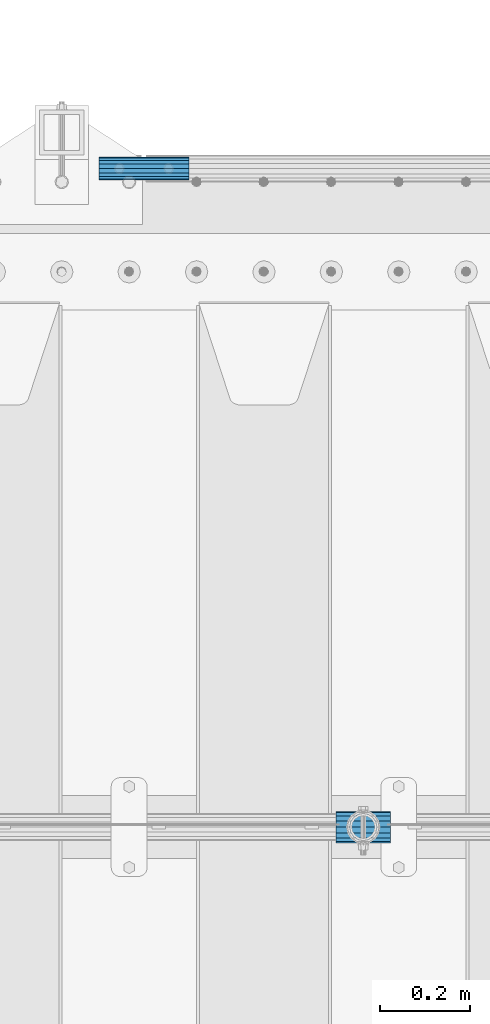
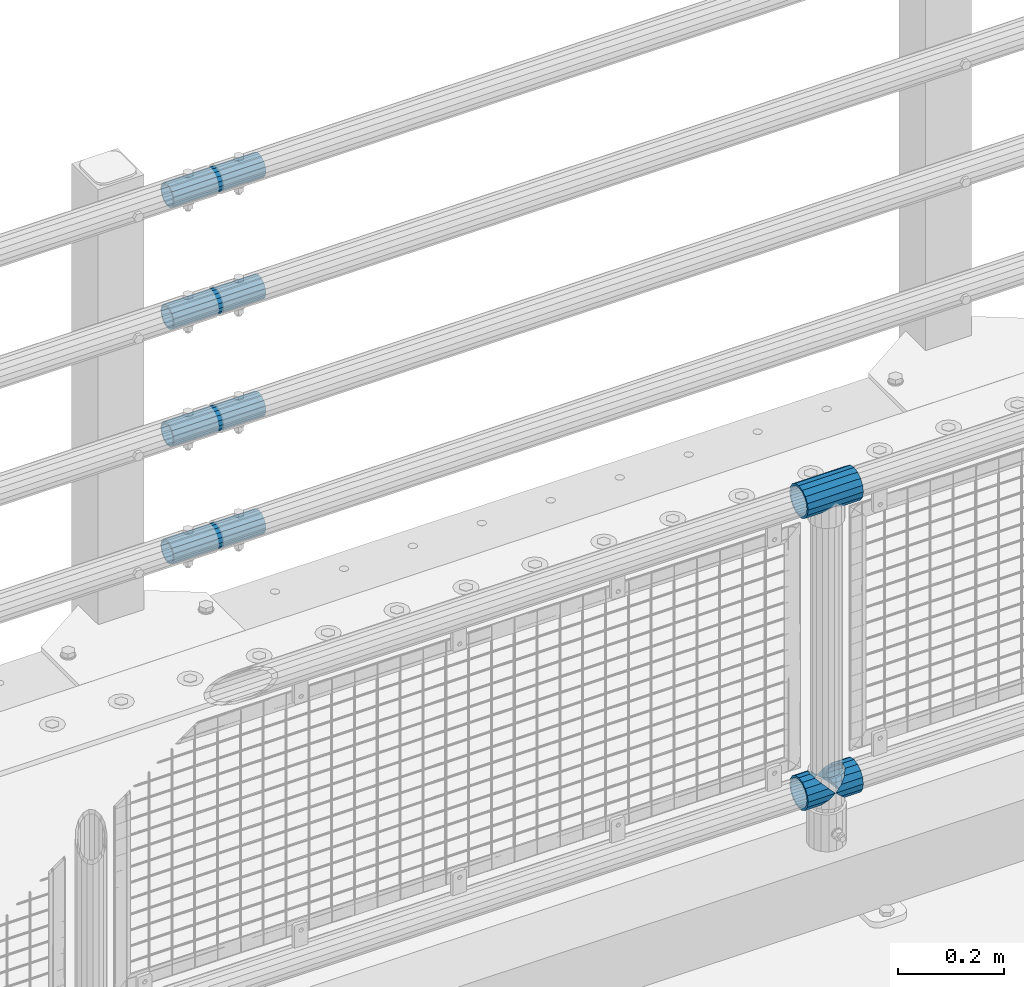
# One storey, part 127 of 208: 7 beams.
"""IFC2X3 building model written with IfcOpenShell, lengths in millimetres."""

from ifc_helpers import new_model, si_unit, frame, origin_with_axes, place, context, subcontext, project, spatial, faceted_brep, material, type_object, element, save


model = new_model("IFC2X3")

# Units and contexts
model_context = context("Model", 3, precision=1e-05, world=origin_with_axes())
body_context = subcontext(model_context, "Body", "Model", "MODEL_VIEW")
ifc_project = project(units=[si_unit("LENGTHUNIT", "METRE", prefix="MILLI"), si_unit("AREAUNIT", "SQUARE_METRE"), si_unit("VOLUMEUNIT", "CUBIC_METRE"), si_unit("MASSUNIT", "GRAM", prefix="KILO"), si_unit("TIMEUNIT", "SECOND"), si_unit("PLANEANGLEUNIT", "RADIAN"), si_unit("SOLIDANGLEUNIT", "STERADIAN"), si_unit("THERMODYNAMICTEMPERATUREUNIT", "DEGREE_CELSIUS"), si_unit("LUMINOUSINTENSITYUNIT", "LUMEN")], contexts=[model_context])

# Site, building, storey
site_placement = place(None, origin_with_axes())
site = spatial("IfcSite", under=ifc_project, at=site_placement, CompositionType="ELEMENT")
building_placement = place(site_placement, origin_with_axes())
building = spatial("IfcBuilding", under=site, at=building_placement, Name="Standard", CompositionType="ELEMENT")
storey_placement = place(building_placement, origin_with_axes())
storey = spatial("IfcBuildingStorey", under=building, at=storey_placement, Name="Undefined", CompositionType="ELEMENT", Elevation=0.0)

# Beams
ifc_material_1 = material(Name="Misc_Undefined")
beam_type_1 = type_object("IfcBeamType", PredefinedType="NOTDEFINED")
beam_1_placement = place(storey_placement, frame((-32289.15, 4664.5, 969.849999999999), z_axis=(0.0, 0.0, 1.0), x_axis=(1.0, 0.0, 0.0)))
element("IfcBeam", 1, at=beam_1_placement, inside=storey, type_object=beam_type_1, material=ifc_material_1, context=body_context, shape_type="Brep", body=[
    faceted_brep([(88.1897438117194, -11.6144421722802, -28.0397438117176), (88.1897438117194, -11.6144421722802, -32.8397438117178), (86.9623795176776, -13.4513226476329, -32.4743655677718), (81.6106908090114, -21.4606908090118, -27.1226768591068), (81.6106908090114, -21.4606908090118, -21.4606908090117), (76.531042407998, -24.8548033587067, -24.8548033587072), (71.7644421722835, -28.0397438117179, -20.0882031229861), (71.7644421722835, -28.0397438117179, -11.6144421722805), (60.1500000000015, -30.3500000000004, -16.6306603983687), (60.1500000000015, -30.35, 0.0), (48.5355578277195, -28.0397438117179, -20.0882031229861), (48.5355578277195, -28.0397438117179, -11.6144421722805), (43.7689575919976, -24.8548033587067, -24.8548033587072), (38.6893091909915, -21.4606908090118, -27.1226768591068), (38.6893091909915, -21.4606908090118, -21.4606908090117), (33.3376204823217, -13.4513226476329, -32.4743655677718), (32.1102561882835, -11.6144421722802, -32.8397438117178), (32.1102561882835, -11.6144421722802, -28.0397438117176), (29.8000000000029, 0.0, -35.15), (29.8000000000029, 0.0, -30.35), (32.1102561882835, 11.6144421722802, -32.8397438117175), (32.1102561882835, 11.6144421722802, -28.0397438117176), (33.3376204823217, 13.4513226476329, -32.4743655677718), (38.6893091909915, 21.4606908090118, -27.122676859108), (38.6893091909915, 21.4606908090118, -21.4606908090117), (43.7689575920012, 24.8548033587067, -24.8548033587072), (48.5355578277195, 28.0397438117179, -20.0882031229838), (48.5355578277195, 28.0397438117179, -11.6144421722805), (60.1500000000015, 30.3500000000004, -16.6306603983671), (60.1500000000015, 30.35, 0.0), (71.7644421722835, 28.0397438117179, -20.0882031229838), (71.7644421722835, 28.0397438117179, -11.6144421722805), (76.5310424080089, 24.8548033587067, -24.8548033587072), (81.6106908090114, 21.4606908090118, -27.122676859108), (81.6106908090114, 21.4606908090118, -21.4606908090117), (86.9623795176776, 13.4513226476329, -32.4743655677718), (88.1897438117194, 11.6144421722802, -32.8397438117175), (88.1897438117194, 11.6144421722802, -28.0397438117176), (90.5, 0.0, -35.15), (90.5, 0.0, -30.35), (0.0, -21.4606908090118, -21.4606908090136), (0.0, -28.0397438117179, -11.6144421722784), (0.0, -11.6144421722802, -28.0397438117143), (0.0, 0.0, -30.3499999999985), (0.0, 11.6144421722802, -28.0397438117143), (0.0, 21.4606908090118, -21.4606908090136), (0.0, 28.0397438117179, -11.6144421722784), (0.0, 30.3500000000004, 0.0), (0.0, 32.4743655677721, -13.4513226476338), (0.0, 35.1499999999996, 0.0), (120.299999999999, 35.1499999999996, 0.0), (120.299999999999, 32.4743655677721, -13.4513226476329), (0.0, 32.4743655677721, 13.4513226476338), (120.299999999999, 32.4743655677721, 13.4513226476329), (0.0, 24.8548033587067, 24.8548033587067), (120.299999999999, 24.8548033587067, 24.8548033587072), (0.0, 13.4513226476329, 32.4743655677739), (120.299999999999, 13.4513226476329, 32.4743655677718), (0.0, 0.0, 35.1499999999996), (120.299999999999, 0.0, 35.15), (0.0, -13.4513226476329, 32.4743655677739), (120.299999999999, -13.4513226476329, 32.4743655677718), (0.0, -24.8548033587067, 24.8548033587067), (120.299999999999, -24.8548033587067, 24.8548033587072), (0.0, -32.4743655677721, 13.4513226476338), (120.299999999999, -32.4743655677721, 13.4513226476329), (0.0, -35.1499999999996, 0.0), (120.299999999999, -35.1499999999996, 0.0), (0.0, -32.4743655677721, -13.4513226476338), (120.299999999999, -32.4743655677721, -13.4513226476329), (0.0, 24.8548033587067, -24.8548033587067), (0.0, 13.4513226476329, -32.4743655677739), (0.0, 0.0, -35.1499999999996), (0.0, -13.4513226476329, -32.4743655677739), (0.0, -24.8548033587067, -24.8548033587067), (0.0, 28.0397438117179, 11.6144421722784), (0.0, 21.4606908090118, 21.4606908090136), (0.0, 11.6144421722802, 28.0397438117143), (0.0, 0.0, 30.3499999999985), (0.0, -11.6144421722802, 28.0397438117143), (0.0, -21.4606908090118, 21.4606908090136), (0.0, -28.0397438117179, 11.6144421722784), (0.0, -30.3500000000004, 0.0), (120.299999999999, -30.3500000000004, 0.0), (120.299999999999, -28.0397438117179, -11.6144421722805), (120.299999999999, -21.4606908090118, -21.4606908090117), (120.299999999999, -11.6144421722802, -28.0397438117176), (120.299999999999, 0.0, -30.35), (120.299999999999, 21.4606908090118, -21.4606908090117), (120.299999999999, 28.0397438117179, -11.6144421722805), (120.299999999999, 11.6144421722802, -28.0397438117176), (120.299999999999, 30.3500000000004, 0.0), (120.299999999999, 28.0397438117179, 11.6144421722805), (120.299999999999, 21.4606908090118, 21.4606908090117), (120.299999999999, 11.6144421722802, 28.0397438117176), (120.299999999999, 0.0, 30.35), (120.299999999999, -11.6144421722802, 28.0397438117176), (120.299999999999, -21.4606908090118, 21.4606908090117), (120.299999999999, -28.0397438117179, 11.6144421722805), (120.299999999999, -24.8548033587067, -24.8548033587072), (120.299999999999, -13.4513226476329, -32.4743655677718), (120.299999999999, 0.0, -35.15), (120.299999999999, 13.4513226476329, -32.4743655677718), (120.299999999999, 24.8548033587067, -24.8548033587072)], [[[0, 1, 2, 3, 4]], [[4, 3, 5, 6, 7]], [[7, 6, 8, 9]], [[9, 8, 10, 11]], [[11, 10, 12, 13, 14]], [[14, 13, 15, 16, 17]], [[17, 16, 18, 19]], [[19, 18, 20, 21]], [[21, 20, 22, 23, 24]], [[24, 23, 25, 26, 27]], [[27, 26, 28, 29]], [[29, 28, 30, 31]], [[31, 30, 32, 33, 34]], [[34, 33, 35, 36, 37]], [[37, 36, 38, 39]], [[39, 38, 1, 0]], [[40, 41, 11, 14]], [[42, 40, 14, 17]], [[43, 42, 17, 19]], [[44, 43, 19, 21]], [[45, 44, 21, 24]], [[46, 45, 24, 27]], [[47, 46, 27, 29]], [[48, 49, 50, 51]], [[49, 52, 53, 50]], [[52, 54, 55, 53]], [[54, 56, 57, 55]], [[56, 58, 59, 57]], [[58, 60, 61, 59]], [[60, 62, 63, 61]], [[62, 64, 65, 63]], [[64, 66, 67, 65]], [[66, 68, 69, 67]], [[64, 62, 60, 58, 56, 54, 52, 49, 48, 70, 71, 72, 73, 74, 68, 66], [41, 40, 42, 43, 44, 45, 46, 47, 75, 76, 77, 78, 79, 80, 81, 82]], [[41, 82, 9, 11]], [[83, 84, 7, 9]], [[84, 85, 4, 7]], [[85, 86, 0, 4]], [[86, 87, 39, 0]], [[88, 89, 31, 34]], [[90, 88, 34, 37]], [[87, 90, 37, 39]], [[89, 91, 29, 31]], [[75, 47, 29, 91, 92]], [[76, 75, 92, 93]], [[77, 76, 93, 94]], [[78, 77, 94, 95]], [[79, 78, 95, 96]], [[80, 79, 96, 97]], [[81, 80, 97, 98]], [[9, 82, 81, 98, 83]], [[99, 100, 101, 102, 103, 51, 50, 53, 55, 57, 59, 61, 63, 65, 67, 69], [97, 96, 95, 94, 93, 92, 91, 89, 88, 90, 87, 86, 85, 84, 83, 98]], [[35, 102, 101, 38, 36]], [[32, 103, 102, 35, 33]], [[28, 26, 25, 70, 48, 51, 103, 32, 30]], [[22, 71, 70, 25, 23]], [[18, 72, 71, 22, 20]], [[73, 72, 18, 16, 15]], [[74, 73, 15, 13, 12]], [[99, 69, 68, 74, 12, 10, 8, 6, 5]], [[100, 99, 5, 3, 2]], [[101, 100, 2, 1, 38]]]),
])
beam_2_placement = place(storey_placement, frame((-32289.15, 4664.5, 298.17), z_axis=(0.0, 1.0, 0.0), x_axis=(1.0, 0.0, 0.0)))
element("IfcBeam", 2, at=beam_2_placement, inside=storey, type_object=beam_type_1, material=ifc_material_1, context=body_context, shape_type="Brep", body=[
    faceted_brep([(60.1500000000015, 0.0, -35.1499999999996), (46.6986773523677, 13.4513226476329, -32.4743655677721), (46.6986773523677, -13.4513226476329, -32.4743655677721), (33.0273231408937, 21.4606908090117, 21.4606908090118), (27.6756344322275, 26.812379517676, 13.4513226476329), (27.6756344322275, 32.4743655677717, 13.4513226476329), (35.2951966412948, 24.8548033587072, 24.8548033587067), (35.2951966412948, 16.3810424080032, 24.8548033587067), (27.3102561882915, 28.0397438117175, 11.6144421722802), (25.0, 30.35, 0.0), (25.0, 35.15, 0.0), (27.6756344322275, 26.8123795176755, -13.4513226476329), (27.6756344322275, 32.4743655677717, -13.4513226476329), (27.3102561882843, 28.0397438117175, -11.6144421722802), (35.2951966412948, 16.3810424080024, -24.8548033587067), (35.2951966412948, 24.8548033587072, -24.8548033587067), (33.0273231408864, 21.4606908090117, -21.4606908090118), (40.0617968770239, 11.6144421722805, -28.0397438117179), (43.5193396016402, 0.0, -30.3500000000004), (40.0617968770239, -11.6144421722805, -28.0397438117179), (35.2951966412948, -16.3810424080032, -24.8548033587067), (35.2951966412948, -24.8548033587072, -24.8548033587067), (33.0273231408864, -21.4606908090117, -21.4606908090118), (27.6756344322275, -26.812379517676, -13.4513226476329), (27.6756344322275, -32.4743655677717, -13.4513226476329), (27.3102561882843, -28.0397438117175, -11.6144421722802), (25.0, -30.35, 0.0), (25.0, -35.15, 0.0), (27.3102561882915, -28.0397438117175, 11.6144421722802), (27.6756344322275, -26.8123795176755, 13.4513226476329), (27.6756344322275, -32.4743655677717, 13.4513226476329), (33.0273231408937, -21.4606908090117, 21.4606908090118), (35.2951966412948, -16.3810424080032, 24.8548033587067), (35.2951966412948, -24.8548033587072, 24.8548033587067), (60.1500000000015, 0.0, 35.1499999999996), (46.6986773523677, -13.4513226476329, 32.4743655677721), (46.6986773523677, 13.4513226476329, 32.4743655677721), (40.0617968770093, -11.6144421722805, 28.0397438117179), (43.519339601633, 0.0, 30.3500000000004), (40.0617968770093, 11.6144421722805, 28.0397438117179), (0.0, -32.4743655677721, -13.4513226476338), (0.0, -24.8548033587067, -24.8548033587067), (0.0, -13.4513226476329, -32.4743655677739), (0.0, 0.0, -35.1499999999996), (0.0, 13.4513226476329, -32.4743655677739), (0.0, 24.8548033587067, -24.8548033587067), (0.0, 32.4743655677721, -13.4513226476338), (0.0, 35.1499999999996, 0.0), (0.0, 32.4743655677721, 13.4513226476338), (0.0, 24.8548033587067, 24.8548033587067), (0.0, 13.4513226476329, 32.4743655677739), (0.0, 0.0, 35.1499999999996), (0.0, -32.4743655677721, 13.4513226476338), (0.0, -35.1499999999996, 0.0), (0.0, -24.8548033587067, 24.8548033587067), (0.0, -13.4513226476329, 32.4743655677739), (0.0, -28.0397438117179, -11.6144421722784), (0.0, -21.4606908090118, -21.4606908090136), (0.0, -11.6144421722802, -28.0397438117143), (0.0, 0.0, -30.3499999999985), (0.0, 11.6144421722802, -28.0397438117143), (0.0, 21.4606908090118, -21.4606908090136), (0.0, 28.0397438117179, -11.6144421722784), (0.0, 30.3500000000004, 0.0), (0.0, 28.0397438117179, 11.6144421722784), (0.0, 21.4606908090118, 21.4606908090136), (0.0, 11.6144421722802, 28.0397438117143), (0.0, 0.0, 30.3499999999985), (0.0, -11.6144421722802, 28.0397438117143), (0.0, -21.4606908090118, 21.4606908090136), (0.0, -28.0397438117179, 11.6144421722784), (0.0, -30.3500000000004, 0.0)], [[[0, 1, 2]], [[3, 4, 5, 6, 7]], [[8, 9, 10, 5, 4]], [[11, 12, 10, 9, 13]], [[14, 15, 12, 11, 16]], [[2, 1, 15, 14, 17, 18, 19, 20, 21]], [[21, 20, 22, 23, 24]], [[24, 23, 25, 26, 27]], [[27, 26, 28, 29, 30]], [[30, 29, 31, 32, 33]], [[34, 35, 36]], [[33, 32, 37, 38, 39, 7, 6, 36, 35]], [[40, 41, 21, 24]], [[41, 42, 2, 21]], [[42, 43, 0, 2]], [[43, 44, 1, 0]], [[44, 45, 15, 1]], [[45, 46, 12, 15]], [[46, 47, 10, 12]], [[47, 48, 5, 10]], [[48, 49, 6, 5]], [[49, 50, 36, 6]], [[50, 51, 34, 36]], [[52, 53, 27, 30]], [[54, 52, 30, 33]], [[55, 54, 33, 35]], [[51, 55, 35, 34]], [[53, 40, 24, 27]], [[52, 54, 55, 51, 50, 49, 48, 47, 46, 45, 44, 43, 42, 41, 40, 53], [56, 57, 58, 59, 60, 61, 62, 63, 64, 65, 66, 67, 68, 69, 70, 71]], [[68, 67, 38, 37]], [[31, 69, 68, 37, 32]], [[28, 70, 69, 31, 29]], [[71, 70, 28, 26]], [[56, 71, 26, 25]], [[57, 56, 25, 23, 22]], [[58, 57, 22, 20, 19]], [[59, 58, 19, 18]], [[60, 59, 18, 17]], [[16, 61, 60, 17, 14]], [[13, 62, 61, 16, 11]], [[63, 62, 13, 9]], [[64, 63, 9, 8]], [[65, 64, 8, 4, 3]], [[66, 65, 3, 7, 39]], [[67, 66, 39, 38]]]),
])
beam_3_placement = place(storey_placement, frame((-32229.0, 4664.5, 298.17), z_axis=(0.0, 1.0, 0.0), x_axis=(1.0, 0.0, 0.0)))
element("IfcBeam", 3, at=beam_3_placement, inside=storey, type_object=beam_type_1, material=ifc_material_1, context=body_context, shape_type="Brep", body=[
    faceted_brep([(0.0, 0.0, 35.1499999999996), (13.4513226476338, 13.4513226476329, 32.4743655677721), (13.4513226476338, -13.4513226476329, 32.4743655677721), (32.4743655677739, -32.4743655677717, -13.4513226476329), (32.4743655677739, -26.8123795176766, -13.4513226476329), (27.1226768591077, -21.4606908090117, -21.4606908090118), (24.8548033587067, -16.3810424080039, -24.8548033587067), (24.8548033587067, -24.8548033587072, -24.8548033587067), (13.4513226476338, -13.4513226476329, -32.4743655677721), (13.4513226476338, 13.4513226476329, -32.4743655677721), (0.0, 0.0, -35.1499999999996), (20.0882031229849, -11.6144421722805, -28.0397438117179), (16.6306603983685, 0.0, -30.3500000000004), (20.0882031229849, 11.6144421722805, -28.0397438117179), (24.8548033587067, 16.3810424080023, -24.8548033587067), (24.8548033587067, 24.8548033587072, -24.8548033587067), (32.4743655677739, 26.8123795176755, -13.4513226476329), (32.4743655677739, 32.4743655677717, -13.4513226476329), (27.1226768591077, 21.4606908090117, -21.4606908090118), (35.1500000000015, 30.35, 0.0), (35.1500000000015, 35.15, 0.0), (32.8397438117172, 28.0397438117175, -11.6144421722802), (32.8397438117172, 28.0397438117175, 11.6144421722802), (32.4743655677739, 26.812379517676, 13.4513226476329), (32.4743655677739, 32.4743655677717, 13.4513226476329), (27.1226768591005, 21.4606908090117, 21.4606908090118), (24.8548033587067, 16.3810424080032, 24.8548033587067), (24.8548033587067, 24.8548033587072, 24.8548033587067), (20.0882031229921, 11.6144421722805, 28.0397438117179), (16.6306603983685, 0.0, 30.3500000000004), (20.0882031229921, -11.6144421722805, 28.0397438117179), (24.8548033587067, -16.3810424080039, 24.8548033587067), (24.8548033587067, -24.8548033587072, 24.8548033587067), (27.1226768591005, -21.4606908090117, 21.4606908090118), (32.4743655677739, -26.8123795176755, 13.4513226476329), (32.4743655677739, -32.4743655677717, 13.4513226476329), (32.8397438117172, -28.0397438117175, 11.6144421722802), (35.1500000000015, -30.35, 0.0), (35.1500000000015, -35.1499999999996, 0.0), (32.8397438117172, -28.0397438117175, -11.6144421722802), (60.1500000000015, -24.8548033587072, -24.8548033587067), (60.1500000000015, -32.4743655677717, -13.4513226476329), (60.1500000000015, -13.4513226476329, -32.4743655677721), (60.1500000000015, 0.0, -35.1499999999996), (60.1500000000015, 13.4513226476329, -32.4743655677721), (60.1500000000015, 24.8548033587072, -24.8548033587067), (60.1500000000015, 32.4743655677717, -13.4513226476329), (60.1500000000015, 35.15, 0.0), (60.1500000000015, 32.4743655677717, 13.4513226476329), (60.1500000000015, 24.8548033587072, 24.8548033587067), (60.1500000000015, 13.4513226476329, 32.4743655677721), (60.1500000000015, 0.0, 35.1499999999996), (60.1500000000015, -13.4513226476329, 32.4743655677721), (60.1500000000015, -24.8548033587072, 24.8548033587067), (60.1500000000015, -32.4743655677717, 13.4513226476329), (60.1500000000015, -35.15, 0.0), (60.1500000000015, -21.4606908090117, 21.4606908090118), (60.1500000000015, -11.6144421722805, 28.0397438117179), (60.1500000000015, 0.0, 30.3500000000004), (60.1500000000015, 11.6144421722805, 28.0397438117179), (60.1500000000015, 21.4606908090117, 21.4606908090118), (60.1500000000015, 28.0397438117175, 11.6144421722802), (60.1500000000015, 30.35, 0.0), (60.1500000000015, 28.0397438117175, -11.6144421722802), (60.1500000000015, 21.4606908090117, -21.4606908090118), (60.1500000000015, 11.6144421722805, -28.0397438117179), (60.1500000000015, 0.0, -30.3500000000004), (60.1500000000015, -11.6144421722805, -28.0397438117179), (60.1500000000015, -21.4606908090117, -21.4606908090118), (60.1500000000015, -28.0397438117175, -11.6144421722802), (60.1500000000015, -30.35, 0.0), (60.1500000000015, -28.0397438117175, 11.6144421722802)], [[[0, 1, 2]], [[3, 4, 5, 6, 7]], [[8, 9, 10]], [[7, 6, 11, 12, 13, 14, 15, 9, 8]], [[16, 17, 15, 14, 18]], [[19, 20, 17, 16, 21]], [[22, 23, 24, 20, 19]], [[25, 26, 27, 24, 23]], [[2, 1, 27, 26, 28, 29, 30, 31, 32]], [[32, 31, 33, 34, 35]], [[35, 34, 36, 37, 38]], [[38, 37, 39, 4, 3]], [[40, 41, 3, 7]], [[42, 40, 7, 8]], [[43, 42, 8, 10]], [[44, 43, 10, 9]], [[45, 44, 9, 15]], [[46, 45, 15, 17]], [[47, 46, 17, 20]], [[48, 47, 20, 24]], [[49, 48, 24, 27]], [[50, 49, 27, 1]], [[51, 50, 1, 0]], [[52, 51, 0, 2]], [[53, 52, 2, 32]], [[54, 53, 32, 35]], [[55, 54, 35, 38]], [[41, 55, 38, 3]], [[40, 42, 43, 44, 45, 46, 47, 48, 49, 50, 51, 52, 53, 54, 55, 41], [56, 57, 58, 59, 60, 61, 62, 63, 64, 65, 66, 67, 68, 69, 70, 71]], [[71, 70, 37, 36]], [[33, 56, 71, 36, 34]], [[30, 57, 56, 33, 31]], [[58, 57, 30, 29]], [[59, 58, 29, 28]], [[60, 59, 28, 26, 25]], [[61, 60, 25, 23, 22]], [[62, 61, 22, 19]], [[63, 62, 19, 21]], [[18, 64, 63, 21, 16]], [[13, 65, 64, 18, 14]], [[66, 65, 13, 12]], [[67, 66, 12, 11]], [[68, 67, 11, 6, 5]], [[69, 68, 5, 4, 39]], [[70, 69, 39, 37]]]),
])
ifc_material_2 = material()
beam_type_2 = type_object("IfcBeamType", PredefinedType="NOTDEFINED")
beam_4_placement = place(storey_placement, frame((-32817.0024970001, 6129.8500000004, 149.849999999725), z_axis=(0.0, 0.0, 1.0), x_axis=(1.0, 0.0, 0.0)))
element("IfcBeam", 4, at=beam_4_placement, inside=storey, type_object=beam_type_2, material=ifc_material_2, context=body_context, shape_type="Brep", body=[
    faceted_brep([(0.0, -21.8999999999996, 0.0), (0.0, -20.2329617619971, 8.38076716879547), (200.0, -20.2329617619971, 8.38076716879547), (200.0, -21.8999999999996, 0.0), (0.0, -15.4856385079856, 15.4856385079854), (200.0, -15.4856385079856, 15.4856385079854), (0.0, -8.3807671687955, 20.2329617619972), (200.0, -8.3807671687955, 20.2329617619972), (0.0, 0.0, 21.9), (200.0, 0.0, 21.9), (0.0, 8.3807671687955, 20.2329617619972), (200.0, 8.3807671687955, 20.2329617619972), (0.0, 15.4856385079856, 15.4856385079854), (200.0, 15.4856385079856, 15.4856385079854), (0.0, 20.2329617619971, 8.38076716879547), (200.0, 20.2329617619971, 8.38076716879547), (0.0, 21.8999999999996, 0.0), (200.0, 21.8999999999996, 0.0), (0.0, 20.2329617619971, -8.38076716879547), (200.0, 20.2329617619971, -8.38076716879547), (0.0, 15.4856385079856, -15.4856385079854), (200.0, 15.4856385079856, -15.4856385079854), (0.0, 8.3807671687955, -20.2329617619972), (200.0, 8.3807671687955, -20.2329617619972), (0.0, 0.0, -21.9), (200.0, 0.0, -21.9), (0.0, -8.3807671687955, -20.2329617619972), (200.0, -8.3807671687955, -20.2329617619972), (0.0, -15.4856385079856, -15.4856385079854), (200.0, -15.4856385079856, -15.4856385079854), (0.0, -20.2329617619971, -8.38076716879547), (200.0, -20.2329617619971, -8.38076716879547), (0.0, -25.5, 0.0), (0.0, -23.5589280790382, -9.7584275253098), (200.0, -23.5589280790382, -9.7584275253098), (200.0, -25.5, 0.0), (0.0, -18.0312229202573, -18.031222920257), (200.0, -18.0312229202573, -18.031222920257), (0.0, -9.75842752530934, -23.5589280790378), (200.0, -9.75842752530934, -23.5589280790378), (0.0, 0.0, -25.5), (200.0, 0.0, -25.5), (0.0, 9.75842752531025, -23.5589280790378), (200.0, 9.75842752531025, -23.5589280790378), (0.0, 18.0312229202573, -18.031222920257), (200.0, 18.0312229202573, -18.031222920257), (0.0, 23.5589280790382, -9.7584275253098), (200.0, 23.5589280790382, -9.7584275253098), (0.0, 25.5, 0.0), (200.0, 25.5, 0.0), (0.0, 23.5589280790382, 9.7584275253098), (200.0, 23.5589280790382, 9.7584275253098), (0.0, 18.0312229202573, 18.031222920257), (200.0, 18.0312229202573, 18.031222920257), (0.0, 9.75842752530934, 23.5589280790378), (200.0, 9.75842752530934, 23.5589280790378), (0.0, 0.0, 25.5), (200.0, 0.0, 25.5), (0.0, -9.75842752530934, 23.5589280790378), (200.0, -9.75842752530934, 23.5589280790378), (0.0, -18.0312229202573, 18.031222920257), (200.0, -18.0312229202573, 18.031222920257), (0.0, -23.5589280790382, 9.7584275253098), (200.0, -23.5589280790382, 9.7584275253098)], [[[0, 1, 2, 3]], [[1, 4, 5, 2]], [[4, 6, 7, 5]], [[6, 8, 9, 7]], [[8, 10, 11, 9]], [[10, 12, 13, 11]], [[12, 14, 15, 13]], [[14, 16, 17, 15]], [[16, 18, 19, 17]], [[18, 20, 21, 19]], [[20, 22, 23, 21]], [[22, 24, 25, 23]], [[24, 26, 27, 25]], [[26, 28, 29, 27]], [[28, 30, 31, 29]], [[30, 0, 3, 31]], [[32, 33, 34, 35]], [[33, 36, 37, 34]], [[36, 38, 39, 37]], [[38, 40, 41, 39]], [[40, 42, 43, 41]], [[42, 44, 45, 43]], [[44, 46, 47, 45]], [[46, 48, 49, 47]], [[48, 50, 51, 49]], [[50, 52, 53, 51]], [[52, 54, 55, 53]], [[54, 56, 57, 55]], [[56, 58, 59, 57]], [[58, 60, 61, 59]], [[60, 62, 63, 61]], [[62, 32, 35, 63]], [[37, 39, 41, 43, 45, 47, 49, 51, 53, 55, 57, 59, 61, 63, 35, 34], [5, 7, 9, 11, 13, 15, 17, 19, 21, 23, 25, 27, 29, 31, 3, 2]], [[62, 60, 58, 56, 54, 52, 50, 48, 46, 44, 42, 40, 38, 36, 33, 32], [30, 28, 26, 24, 22, 20, 18, 16, 14, 12, 10, 8, 6, 4, 1, 0]]]),
])
beam_5_placement = place(storey_placement, frame((-32817.0024970001, 6129.8500000004, 420.149999999724), z_axis=(0.0, 0.0, 1.0), x_axis=(1.0, 0.0, 0.0)))
element("IfcBeam", 5, at=beam_5_placement, inside=storey, type_object=beam_type_2, material=ifc_material_2, context=body_context, shape_type="Brep", body=[
    faceted_brep([(0.0, -21.8999999999996, 0.0), (0.0, -20.2329617619971, 8.38076716879547), (200.0, -20.2329617619971, 8.38076716879547), (200.0, -21.8999999999996, 0.0), (0.0, -15.4856385079856, 15.4856385079854), (200.0, -15.4856385079856, 15.4856385079854), (0.0, -8.3807671687955, 20.2329617619972), (200.0, -8.3807671687955, 20.2329617619972), (0.0, 0.0, 21.9), (200.0, 0.0, 21.9), (0.0, 8.3807671687955, 20.2329617619972), (200.0, 8.3807671687955, 20.2329617619972), (0.0, 15.4856385079856, 15.4856385079854), (200.0, 15.4856385079856, 15.4856385079854), (0.0, 20.2329617619971, 8.38076716879547), (200.0, 20.2329617619971, 8.38076716879547), (0.0, 21.8999999999996, 0.0), (200.0, 21.8999999999996, 0.0), (0.0, 20.2329617619971, -8.38076716879547), (200.0, 20.2329617619971, -8.38076716879547), (0.0, 15.4856385079856, -15.4856385079854), (200.0, 15.4856385079856, -15.4856385079854), (0.0, 8.3807671687955, -20.2329617619972), (200.0, 8.3807671687955, -20.2329617619972), (0.0, 0.0, -21.9), (200.0, 0.0, -21.9), (0.0, -8.3807671687955, -20.2329617619972), (200.0, -8.3807671687955, -20.2329617619972), (0.0, -15.4856385079856, -15.4856385079854), (200.0, -15.4856385079856, -15.4856385079854), (0.0, -20.2329617619971, -8.38076716879547), (200.0, -20.2329617619971, -8.38076716879547), (0.0, -25.5, 0.0), (0.0, -23.5589280790382, -9.7584275253098), (200.0, -23.5589280790382, -9.7584275253098), (200.0, -25.5, 0.0), (0.0, -18.0312229202573, -18.031222920257), (200.0, -18.0312229202573, -18.031222920257), (0.0, -9.75842752530934, -23.5589280790378), (200.0, -9.75842752530934, -23.5589280790378), (0.0, 0.0, -25.5), (200.0, 0.0, -25.5), (0.0, 9.75842752531025, -23.5589280790378), (200.0, 9.75842752531025, -23.5589280790378), (0.0, 18.0312229202573, -18.031222920257), (200.0, 18.0312229202573, -18.031222920257), (0.0, 23.5589280790382, -9.7584275253098), (200.0, 23.5589280790382, -9.7584275253098), (0.0, 25.5, 0.0), (200.0, 25.5, 0.0), (0.0, 23.5589280790382, 9.7584275253098), (200.0, 23.5589280790382, 9.7584275253098), (0.0, 18.0312229202573, 18.031222920257), (200.0, 18.0312229202573, 18.031222920257), (0.0, 9.75842752530934, 23.5589280790378), (200.0, 9.75842752530934, 23.5589280790378), (0.0, 0.0, 25.5), (200.0, 0.0, 25.5), (0.0, -9.75842752530934, 23.5589280790378), (200.0, -9.75842752530934, 23.5589280790378), (0.0, -18.0312229202573, 18.031222920257), (200.0, -18.0312229202573, 18.031222920257), (0.0, -23.5589280790382, 9.7584275253098), (200.0, -23.5589280790382, 9.7584275253098)], [[[0, 1, 2, 3]], [[1, 4, 5, 2]], [[4, 6, 7, 5]], [[6, 8, 9, 7]], [[8, 10, 11, 9]], [[10, 12, 13, 11]], [[12, 14, 15, 13]], [[14, 16, 17, 15]], [[16, 18, 19, 17]], [[18, 20, 21, 19]], [[20, 22, 23, 21]], [[22, 24, 25, 23]], [[24, 26, 27, 25]], [[26, 28, 29, 27]], [[28, 30, 31, 29]], [[30, 0, 3, 31]], [[32, 33, 34, 35]], [[33, 36, 37, 34]], [[36, 38, 39, 37]], [[38, 40, 41, 39]], [[40, 42, 43, 41]], [[42, 44, 45, 43]], [[44, 46, 47, 45]], [[46, 48, 49, 47]], [[48, 50, 51, 49]], [[50, 52, 53, 51]], [[52, 54, 55, 53]], [[54, 56, 57, 55]], [[56, 58, 59, 57]], [[58, 60, 61, 59]], [[60, 62, 63, 61]], [[62, 32, 35, 63]], [[37, 39, 41, 43, 45, 47, 49, 51, 53, 55, 57, 59, 61, 63, 35, 34], [5, 7, 9, 11, 13, 15, 17, 19, 21, 23, 25, 27, 29, 31, 3, 2]], [[62, 60, 58, 56, 54, 52, 50, 48, 46, 44, 42, 40, 38, 36, 33, 32], [30, 28, 26, 24, 22, 20, 18, 16, 14, 12, 10, 8, 6, 4, 1, 0]]]),
])
beam_6_placement = place(storey_placement, frame((-32817.0024970001, 6129.8500000004, 969.849999999725), z_axis=(0.0, 0.0, 1.0), x_axis=(1.0, 0.0, 0.0)))
element("IfcBeam", 6, at=beam_6_placement, inside=storey, type_object=beam_type_2, material=ifc_material_2, context=body_context, shape_type="Brep", body=[
    faceted_brep([(0.0, -21.8999999999996, 0.0), (0.0, -20.2329617619971, 8.38076716879547), (200.0, -20.2329617619971, 8.38076716879547), (200.0, -21.8999999999996, 0.0), (0.0, -15.4856385079856, 15.4856385079854), (200.0, -15.4856385079856, 15.4856385079854), (0.0, -8.3807671687955, 20.2329617619972), (200.0, -8.3807671687955, 20.2329617619972), (0.0, 0.0, 21.9), (200.0, 0.0, 21.9), (0.0, 8.3807671687955, 20.2329617619972), (200.0, 8.3807671687955, 20.2329617619972), (0.0, 15.4856385079856, 15.4856385079854), (200.0, 15.4856385079856, 15.4856385079854), (0.0, 20.2329617619971, 8.38076716879547), (200.0, 20.2329617619971, 8.38076716879547), (0.0, 21.8999999999996, 0.0), (200.0, 21.8999999999996, 0.0), (0.0, 20.2329617619971, -8.38076716879547), (200.0, 20.2329617619971, -8.38076716879547), (0.0, 15.4856385079856, -15.4856385079854), (200.0, 15.4856385079856, -15.4856385079854), (0.0, 8.3807671687955, -20.2329617619972), (200.0, 8.3807671687955, -20.2329617619972), (0.0, 0.0, -21.9), (200.0, 0.0, -21.9), (0.0, -8.3807671687955, -20.2329617619972), (200.0, -8.3807671687955, -20.2329617619972), (0.0, -15.4856385079856, -15.4856385079854), (200.0, -15.4856385079856, -15.4856385079854), (0.0, -20.2329617619971, -8.38076716879547), (200.0, -20.2329617619971, -8.38076716879547), (0.0, -25.5, 0.0), (0.0, -23.5589280790382, -9.7584275253098), (200.0, -23.5589280790382, -9.7584275253098), (200.0, -25.5, 0.0), (0.0, -18.0312229202573, -18.031222920257), (200.0, -18.0312229202573, -18.031222920257), (0.0, -9.75842752530934, -23.5589280790378), (200.0, -9.75842752530934, -23.5589280790378), (0.0, 0.0, -25.5), (200.0, 0.0, -25.5), (0.0, 9.75842752531025, -23.5589280790378), (200.0, 9.75842752531025, -23.5589280790378), (0.0, 18.0312229202573, -18.031222920257), (200.0, 18.0312229202573, -18.031222920257), (0.0, 23.5589280790382, -9.7584275253098), (200.0, 23.5589280790382, -9.7584275253098), (0.0, 25.5, 0.0), (200.0, 25.5, 0.0), (0.0, 23.5589280790382, 9.7584275253098), (200.0, 23.5589280790382, 9.7584275253098), (0.0, 18.0312229202573, 18.031222920257), (200.0, 18.0312229202573, 18.031222920257), (0.0, 9.75842752530934, 23.5589280790378), (200.0, 9.75842752530934, 23.5589280790378), (0.0, 0.0, 25.5), (200.0, 0.0, 25.5), (0.0, -9.75842752530934, 23.5589280790378), (200.0, -9.75842752530934, 23.5589280790378), (0.0, -18.0312229202573, 18.031222920257), (200.0, -18.0312229202573, 18.031222920257), (0.0, -23.5589280790382, 9.7584275253098), (200.0, -23.5589280790382, 9.7584275253098)], [[[0, 1, 2, 3]], [[1, 4, 5, 2]], [[4, 6, 7, 5]], [[6, 8, 9, 7]], [[8, 10, 11, 9]], [[10, 12, 13, 11]], [[12, 14, 15, 13]], [[14, 16, 17, 15]], [[16, 18, 19, 17]], [[18, 20, 21, 19]], [[20, 22, 23, 21]], [[22, 24, 25, 23]], [[24, 26, 27, 25]], [[26, 28, 29, 27]], [[28, 30, 31, 29]], [[30, 0, 3, 31]], [[32, 33, 34, 35]], [[33, 36, 37, 34]], [[36, 38, 39, 37]], [[38, 40, 41, 39]], [[40, 42, 43, 41]], [[42, 44, 45, 43]], [[44, 46, 47, 45]], [[46, 48, 49, 47]], [[48, 50, 51, 49]], [[50, 52, 53, 51]], [[52, 54, 55, 53]], [[54, 56, 57, 55]], [[56, 58, 59, 57]], [[58, 60, 61, 59]], [[60, 62, 63, 61]], [[62, 32, 35, 63]], [[37, 39, 41, 43, 45, 47, 49, 51, 53, 55, 57, 59, 61, 63, 35, 34], [5, 7, 9, 11, 13, 15, 17, 19, 21, 23, 25, 27, 29, 31, 3, 2]], [[62, 60, 58, 56, 54, 52, 50, 48, 46, 44, 42, 40, 38, 36, 33, 32], [30, 28, 26, 24, 22, 20, 18, 16, 14, 12, 10, 8, 6, 4, 1, 0]]]),
])
beam_7_placement = place(storey_placement, frame((-32817.0024970001, 6129.8500000004, 689.849999999725), z_axis=(0.0, 0.0, 1.0), x_axis=(1.0, 0.0, 0.0)))
element("IfcBeam", 7, at=beam_7_placement, inside=storey, type_object=beam_type_2, material=ifc_material_2, context=body_context, shape_type="Brep", body=[
    faceted_brep([(0.0, -21.8999999999996, 0.0), (0.0, -20.2329617619971, 8.38076716879547), (200.0, -20.2329617619971, 8.38076716879547), (200.0, -21.8999999999996, 0.0), (0.0, -15.4856385079856, 15.4856385079854), (200.0, -15.4856385079856, 15.4856385079854), (0.0, -8.3807671687955, 20.2329617619972), (200.0, -8.3807671687955, 20.2329617619972), (0.0, 0.0, 21.9), (200.0, 0.0, 21.9), (0.0, 8.3807671687955, 20.2329617619972), (200.0, 8.3807671687955, 20.2329617619972), (0.0, 15.4856385079856, 15.4856385079854), (200.0, 15.4856385079856, 15.4856385079854), (0.0, 20.2329617619971, 8.38076716879547), (200.0, 20.2329617619971, 8.38076716879547), (0.0, 21.8999999999996, 0.0), (200.0, 21.8999999999996, 0.0), (0.0, 20.2329617619971, -8.38076716879547), (200.0, 20.2329617619971, -8.38076716879547), (0.0, 15.4856385079856, -15.4856385079854), (200.0, 15.4856385079856, -15.4856385079854), (0.0, 8.3807671687955, -20.2329617619972), (200.0, 8.3807671687955, -20.2329617619972), (0.0, 0.0, -21.9), (200.0, 0.0, -21.9), (0.0, -8.3807671687955, -20.2329617619972), (200.0, -8.3807671687955, -20.2329617619972), (0.0, -15.4856385079856, -15.4856385079854), (200.0, -15.4856385079856, -15.4856385079854), (0.0, -20.2329617619971, -8.38076716879547), (200.0, -20.2329617619971, -8.38076716879547), (0.0, -25.5, 0.0), (0.0, -23.5589280790382, -9.7584275253098), (200.0, -23.5589280790382, -9.7584275253098), (200.0, -25.5, 0.0), (0.0, -18.0312229202573, -18.031222920257), (200.0, -18.0312229202573, -18.031222920257), (0.0, -9.75842752530934, -23.5589280790378), (200.0, -9.75842752530934, -23.5589280790378), (0.0, 0.0, -25.5), (200.0, 0.0, -25.5), (0.0, 9.75842752531025, -23.5589280790378), (200.0, 9.75842752531025, -23.5589280790378), (0.0, 18.0312229202573, -18.031222920257), (200.0, 18.0312229202573, -18.031222920257), (0.0, 23.5589280790382, -9.7584275253098), (200.0, 23.5589280790382, -9.7584275253098), (0.0, 25.5, 0.0), (200.0, 25.5, 0.0), (0.0, 23.5589280790382, 9.7584275253098), (200.0, 23.5589280790382, 9.7584275253098), (0.0, 18.0312229202573, 18.031222920257), (200.0, 18.0312229202573, 18.031222920257), (0.0, 9.75842752530934, 23.5589280790378), (200.0, 9.75842752530934, 23.5589280790378), (0.0, 0.0, 25.5), (200.0, 0.0, 25.5), (0.0, -9.75842752530934, 23.5589280790378), (200.0, -9.75842752530934, 23.5589280790378), (0.0, -18.0312229202573, 18.031222920257), (200.0, -18.0312229202573, 18.031222920257), (0.0, -23.5589280790382, 9.7584275253098), (200.0, -23.5589280790382, 9.7584275253098)], [[[0, 1, 2, 3]], [[1, 4, 5, 2]], [[4, 6, 7, 5]], [[6, 8, 9, 7]], [[8, 10, 11, 9]], [[10, 12, 13, 11]], [[12, 14, 15, 13]], [[14, 16, 17, 15]], [[16, 18, 19, 17]], [[18, 20, 21, 19]], [[20, 22, 23, 21]], [[22, 24, 25, 23]], [[24, 26, 27, 25]], [[26, 28, 29, 27]], [[28, 30, 31, 29]], [[30, 0, 3, 31]], [[32, 33, 34, 35]], [[33, 36, 37, 34]], [[36, 38, 39, 37]], [[38, 40, 41, 39]], [[40, 42, 43, 41]], [[42, 44, 45, 43]], [[44, 46, 47, 45]], [[46, 48, 49, 47]], [[48, 50, 51, 49]], [[50, 52, 53, 51]], [[52, 54, 55, 53]], [[54, 56, 57, 55]], [[56, 58, 59, 57]], [[58, 60, 61, 59]], [[60, 62, 63, 61]], [[62, 32, 35, 63]], [[37, 39, 41, 43, 45, 47, 49, 51, 53, 55, 57, 59, 61, 63, 35, 34], [5, 7, 9, 11, 13, 15, 17, 19, 21, 23, 25, 27, 29, 31, 3, 2]], [[62, 60, 58, 56, 54, 52, 50, 48, 46, 44, 42, 40, 38, 36, 33, 32], [30, 28, 26, 24, 22, 20, 18, 16, 14, 12, 10, 8, 6, 4, 1, 0]]]),
])

save(model, "model.ifc")
